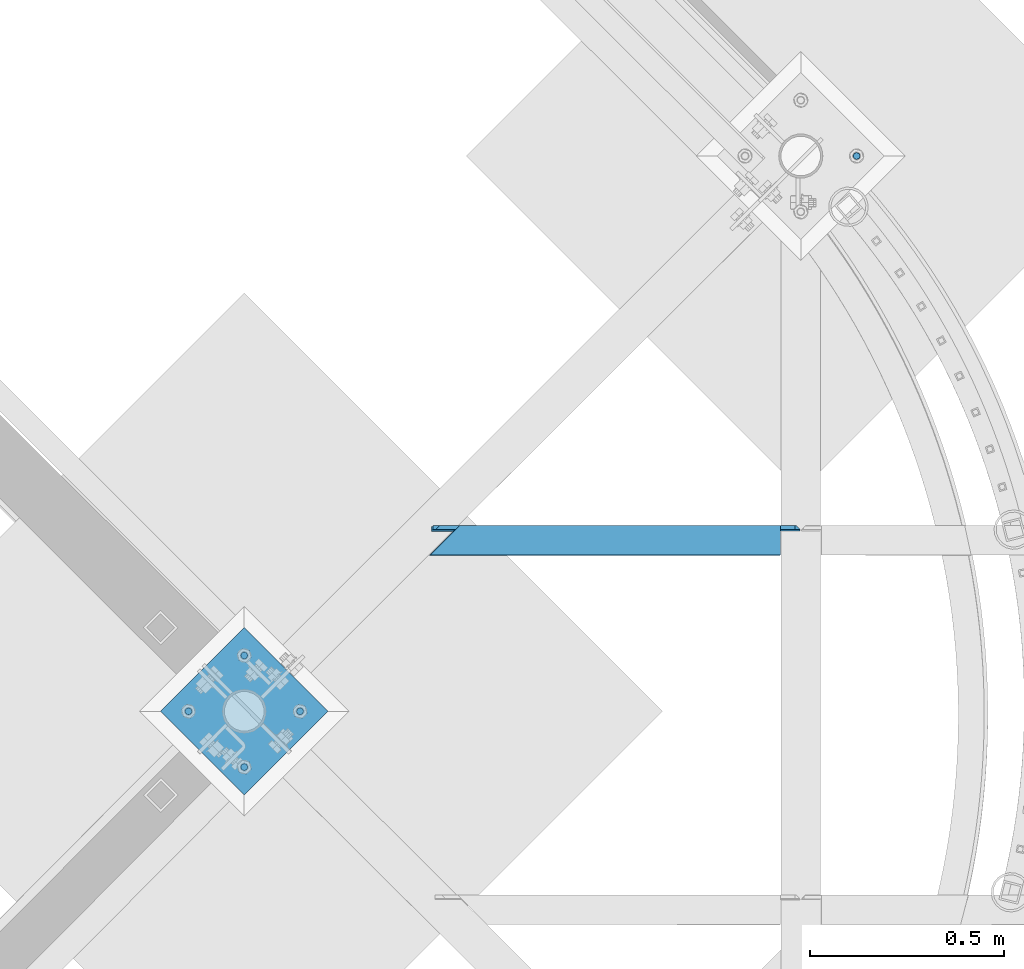
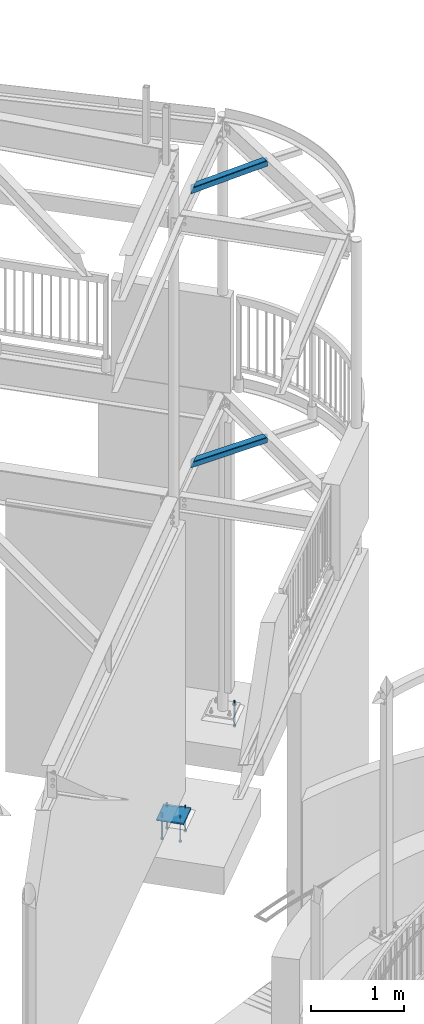
# One storey, part 521 of 975: 9 beams.
"""IFC2X3 building model written with IfcOpenShell, lengths in millimetres."""

from ifc_helpers import new_model, si_unit, frame, origin_with_axes, place, context, subcontext, project, spatial, faceted_brep, material, type_object, element, save


model = new_model("IFC2X3")

# Units and contexts
model_context = context("Model", 3, precision=1e-05, world=origin_with_axes())
body_context = subcontext(model_context, "Body", "Model", "MODEL_VIEW")
ifc_project = project(units=[si_unit("LENGTHUNIT", "METRE", prefix="MILLI"), si_unit("AREAUNIT", "SQUARE_METRE"), si_unit("VOLUMEUNIT", "CUBIC_METRE"), si_unit("MASSUNIT", "GRAM", prefix="KILO"), si_unit("TIMEUNIT", "SECOND"), si_unit("PLANEANGLEUNIT", "RADIAN"), si_unit("SOLIDANGLEUNIT", "STERADIAN"), si_unit("THERMODYNAMICTEMPERATUREUNIT", "DEGREE_CELSIUS"), si_unit("LUMINOUSINTENSITYUNIT", "LUMEN")], contexts=[model_context])

# Site, building, storey
site_placement = place(None, origin_with_axes())
site = spatial("IfcSite", under=ifc_project, at=site_placement, CompositionType="ELEMENT")
building_placement = place(site_placement, origin_with_axes())
building = spatial("IfcBuilding", under=site, at=building_placement, Name="Undefined", CompositionType="ELEMENT")
storey_placement = place(building_placement, origin_with_axes())
storey = spatial("IfcBuildingStorey", under=building, at=storey_placement, Name="Undefined", CompositionType="ELEMENT", Elevation=0.0)

# Beams
ifc_material_1 = material(Name="STEEL/A36")
beam_type_1 = type_object("IfcBeamType", Name="L5X3X3/8", PredefinedType="NOTDEFINED")
beam_1_placement = place(storey_placement, frame((35537.7749999909, 12106.8041668458, 3873.5), z_axis=(0.0, 0.0, -1.0), x_axis=(-0.999999999999998, 6.90000001668524e-08, 0.0)))
element("IfcBeam", 1, at=beam_1_placement, inside=storey, type_object=beam_type_1, material=ifc_material_1, Name="ANGLE", ObjectType="L5X3X3/8", context=body_context, shape_type="Brep", body=[
    faceted_brep([(11.9062518201463, 38.1000002942765, 63.5000000000409), (11.9062518201463, 38.1000000000004, -50.8000004849969), (2.38125152588327, 28.5750000000007, -41.2750001907348), (2.38125152588327, 28.5750000000007, 63.5), (52.3875000000044, -38.1000000000004, -53.9749999999999), (52.3875000000044, -38.1000000000004, -63.5), (955.445198298534, -38.1000000000004, -63.5), (955.445198298941, -38.1000000000004, -53.9749999999999), (52.3875000000044, 28.5750000000007, -53.9749999999999), (888.622206313601, 28.5750000000007, -53.9749999999999), (15.0812513351484, 28.5750000000007, -53.9749999999999), (15.0812513351484, 38.1000000000004, -53.9749999999999), (52.3875000000044, 38.1000000000004, -53.9749999999999), (52.3875000000044, 38.1000000000004, -63.5), (879.076064601009, 38.1000000000004, -63.5), (879.07606460141, 38.1000000000004, -53.9749999995543), (929.646098136363, 38.1000000000004, -53.9749999995488), (939.192239848555, 28.5750000000007, -53.9749999999999), (947.626553754235, 38.1000000000004, -41.2750001902818), (947.626553755501, 28.5750000000007, -48.0176545750301), (947.626553755501, 28.5750003814701, 63.5), (947.626553754235, 38.1000000000004, 63.5)], [[[0, 1, 2, 3]], [[4, 5, 6, 7]], [[8, 4, 7, 9]], [[10, 11, 12, 8]], [[4, 8, 12, 13, 5]], [[5, 13, 14, 6]], [[7, 6, 14, 15, 9]], [[9, 15, 16, 17]], [[17, 16, 18, 19]], [[20, 19, 18, 21]], [[20, 21, 0, 3]], [[10, 8, 9, 17, 19, 20, 3, 2]], [[11, 10, 2, 1]], [[21, 18, 16, 15, 14, 13, 12, 11, 1, 0]]]),
])
beam_2_placement = place(storey_placement, frame((35539.9412127921, 12104.6101987694, 7490.16964449473), z_axis=(0.0341135870818107, -0.0348791829935672, -0.998809143815831), x_axis=(-0.999417962204208, -0.00119054700024391, -0.0340928060069665)))
element("IfcBeam", 2, at=beam_2_placement, inside=storey, type_object=beam_type_1, material=ifc_material_1, Name="ANGLE", ObjectType="L5X3X3/8", context=body_context, shape_type="Brep", body=[
    faceted_brep([(16.248132890425, 38.1000002259043, 63.4999999999727), (12.4534426586179, 38.0999999999676, -47.6721722449001), (3.25891820371908, 28.5749999999734, -37.827783942962), (6.71758545988268, 28.5750000000407, 63.4999999999727), (54.2598028495704, 38.0999999999731, -50.9471839962816), (54.2598028496504, 28.5749999999734, -50.9471839980215), (14.2363025495142, 28.574999999968, -49.5810436898209), (14.236302559053, 38.0999999999676, -49.5810436884067), (54.1564530319665, -38.1000000000258, -53.9749999999822), (53.8313318822111, -38.1000000000313, -63.4999999999791), (957.55596462173, -38.0999999998858, -63.50000000002), (957.881085768073, -38.0999999998821, -53.9750000000231), (54.156453031268, 28.5749999999698, -53.9749999999813), (891.027517890245, 28.5750000001062, -53.9750000000204), (53.831331881418, 38.099999999964, -63.4999999999773), (881.151887132146, 38.100000000095, -63.5000000000155), (881.608963766485, 38.0999998951484, -50.1091301925117), (891.1483590969, 28.575000000108, -50.4347427057555), (939.009241421154, 38.0999999493579, -52.0683999112998), (939.008087242706, 28.5750000001153, -52.1021968201758), (952.135102398344, 28.5749999877098, -39.8086409113939), (952.135102407483, 38.099999965596, -39.8086409100097), (955.661383111757, 38.1000000001932, 63.4999999999309), (955.661383112987, 28.5749998870779, 63.49999999993), (58.1662805450396, 28.5750000000498, 63.4999999999709), (58.1662805449741, 38.1000000000495, 63.4999999999709)], [[[0, 1, 2, 3]], [[4, 5, 6, 7]], [[8, 9, 10, 11]], [[12, 8, 11, 13]], [[5, 4, 14, 9, 8, 12]], [[9, 14, 15, 10]], [[11, 10, 15, 16, 17, 13]], [[17, 16, 18, 19]], [[20, 19, 18, 21]], [[22, 23, 20, 21]], [[24, 23, 22, 25, 0, 3]], [[6, 5, 12, 13, 17, 19, 20, 23, 24, 3, 2]], [[7, 6, 2, 1]], [[25, 22, 21, 18, 16, 15, 14, 4, 7, 1, 0]]]),
])
beam_type_2 = type_object("IfcBeamType", PredefinedType="NOTDEFINED")
beam_3_placement = place(storey_placement, frame((34212.0255734525, 11558.7744265471, -257.175000000002), z_axis=(-0.707106781186548, -0.707106781186548, 0.0), x_axis=(-0.707106781186601, 0.707106781186494, 2.36468622460961e-14)))
element("IfcBeam", 3, at=beam_3_placement, inside=storey, type_object=beam_type_2, material=ifc_material_1, Name="PLATE", context=body_context, shape_type="Brep", body=[
    faceted_brep([(0.0, 9.52499999999964, -152.4), (0.0, 9.52499999999964, 152.4), (304.799999999152, 9.52499999999964, 152.4), (304.799999999152, 9.52499999999964, -152.4), (0.0, -9.52499999999964, 152.4), (304.799999999152, -9.52499999999964, 152.4), (0.0, -9.52499999999964, -152.4), (304.799999999152, -9.52499999999964, -152.4)], [[[0, 1, 2, 3]], [[1, 4, 5, 2]], [[4, 6, 7, 5]], [[6, 0, 3, 7]], [[5, 7, 3, 2]], [[6, 4, 1, 0]]]),
])
ifc_material_2 = material(Name="STEEL/F1554-36")
beam_type_3 = type_object("IfcBeamType", PredefinedType="NOTDEFINED")
beam_4_placement = place(storey_placement, frame((35681.4590946862, 13096.8750013477, -304.799999999999), z_axis=(-0.707106781186601, 0.707106781186494, 2.36468622460961e-14), x_axis=(0.0, 0.0, -1.0)))
element("IfcBeam", 4, at=beam_4_placement, inside=storey, type_object=beam_type_3, material=ifc_material_2, Name="HEADED_ANCHOR_BOLT", context=body_context, shape_type="Brep", body=[
    faceted_brep([(209.543749999999, -9.13000011446275, 15.8100004196049), (209.543749999999, -18.2600002288382, 4.72937244921923e-11), (228.593749999998, -18.2600002288382, 4.72937244921923e-11), (228.593749999998, -9.13000011446275, 15.8100004196049), (209.543749999999, 9.13000011438271, 15.8100004195576), (228.593749999998, 9.13000011438271, 15.8100004195576), (209.543749999999, 18.2600002288382, -4.72937244921923e-11), (228.593749999998, 18.2600002288382, -4.72937244921923e-11), (209.543749999999, 9.13000011446275, -15.8100004196049), (228.593749999998, 9.13000011446275, -15.8100004196049), (209.543749999999, -9.13000011438271, -15.8100004195576), (228.593749999998, -9.13000011438271, -15.8100004195576), (209.543749999999, -4.4776800552936, 9.29799844178979), (209.543749999999, -8.068500660469, 6.43441456491473), (209.543749999999, -10.0612557561763, 2.2964159705416), (209.543749999999, -10.0612557561617, -2.29641597048976), (209.543749999999, -8.0685006604399, -6.4344145648729), (209.543749999999, -4.47768005524995, -9.29799844176705), (209.543749999999, 2.91038304567337e-11, -10.3199996948015), (209.543749999999, 4.4776800552936, -9.29799844178979), (209.543749999999, 8.068500660469, -6.43441456491473), (209.543749999999, 10.0612557561763, -2.2964159705416), (209.543749999999, 10.0612557561617, 2.29641597048976), (209.543749999999, 8.0685006604399, 6.4344145648729), (209.543749999999, 4.47768005524995, 9.29799844176705), (209.543749999999, -2.91038304567337e-11, 10.3199996948015), (228.593749999998, -2.91038304567337e-11, 10.3199996948015), (228.593749999998, -4.4776800552936, 9.29799844178979), (228.593749999998, -8.068500660469, 6.43441456491473), (228.593749999998, -10.0612557561763, 2.2964159705416), (228.593749999998, -10.0612557561617, -2.29641597048976), (228.593749999998, -8.0685006604399, -6.4344145648729), (228.593749999998, -4.47768005524995, -9.29799844176705), (228.593749999998, 2.91038304567337e-11, -10.3199996948015), (228.593749999998, 4.4776800552936, -9.29799844178979), (228.593749999998, 8.068500660469, -6.43441456491473), (228.593749999998, 10.0612557561763, -2.2964159705416), (228.593749999998, 10.0612557561617, 2.29641597048976), (228.593749999998, 8.0685006604399, 6.4344145648729), (228.593749999998, 4.47768005524995, 9.29799844176705), (0.0, -6.73519209080223, 6.73519209080186), (0.0, -9.52499999999964, 0.0), (228.6, -9.52500000000146, 0.0), (228.6, -6.73519209080405, 6.73519209080223), (-9.87109982941227e-13, -1.20792265079217e-13, 9.52499961853027), (228.6, 0.0, 9.52499999999964), (0.0, 6.73519209080223, 6.73519209080186), (228.6, 6.73519209080405, 6.73519209080223), (0.0, 9.52499999999964, 0.0), (228.6, 9.52500000000146, 0.0), (0.0, 6.73519209080223, -6.73519209080186), (228.6, 6.73519209080405, -6.73519209080223), (2.95075507493764e-12, -1.20792265079217e-13, -9.52499961853027), (228.6, 0.0, -9.52499999999964), (-114.297914995421, -6.36396103067818, 6.36396103068091), (-114.297914995421, -2.18278728425503e-11, 8.99999999997999), (-114.297914995421, 6.36396103064908, 6.36396103064817), (-114.297914995421, 8.99999999997817, -2.27373675443232e-11), (-114.297914995421, 6.36396103067818, -6.36396103068091), (-114.297914995421, 2.18278728425503e-11, -8.99999999997999), (-114.297914995421, -6.36396103064908, -6.36396103064817), (-114.297914995421, -8.99999999997817, 2.27373675443232e-11), (0.0149743263646087, 6.36396103067818, -6.36396103067909), (0.0149743263646087, 0.0, -9.0), (0.0149743263646087, -6.36396103067818, -6.36396103067909), (0.0149743263987148, -8.9999995411581, -1.00796984270346e-06), (0.0149743263646087, -6.36396103067818, 6.36396103067909), (0.0149743263646087, 0.0, 9.0), (0.0149743263646087, 6.36396103067818, 6.36396103067909), (0.0149743263987148, 9.0000004588419, -1.00796984270346e-06), (0.0, -6.73519209080223, -6.73519209080186), (228.6, -6.73519209080405, -6.73519209080223)], [[[0, 1, 2, 3]], [[4, 0, 3, 5]], [[6, 4, 5, 7]], [[8, 6, 7, 9]], [[10, 8, 9, 11]], [[0, 4, 6, 8, 10, 1], [12, 13, 14, 15, 16, 17, 18, 19, 20, 21, 22, 23, 24, 25]], [[12, 25, 26, 27]], [[13, 12, 27, 28]], [[14, 13, 28, 29]], [[15, 14, 29, 30]], [[16, 15, 30, 31]], [[17, 16, 31, 32]], [[18, 17, 32, 33]], [[19, 18, 33, 34]], [[20, 19, 34, 35]], [[21, 20, 35, 36]], [[22, 21, 36, 37]], [[23, 22, 37, 38]], [[24, 23, 38, 39]], [[25, 24, 39, 26]], [[9, 7, 5, 3, 2, 11], [38, 37, 36, 35, 34, 33, 32, 31, 30, 29, 28, 27, 26, 39]], [[1, 10, 11, 2]], [[40, 41, 42, 43]], [[44, 40, 43, 45]], [[46, 44, 45, 47]], [[48, 46, 47, 49]], [[50, 48, 49, 51]], [[52, 50, 51, 53]], [[54, 55, 56, 57, 58, 59, 60, 61]], [[59, 58, 62, 63]], [[60, 59, 63, 64]], [[61, 60, 64, 65]], [[54, 61, 65, 66]], [[55, 54, 66, 67]], [[56, 55, 67, 68]], [[57, 56, 68, 69]], [[58, 57, 69, 62]], [[40, 44, 46, 48, 50, 52, 70, 41], [68, 67, 66, 65, 64, 63, 62, 69]], [[41, 70, 71, 42]], [[53, 51, 49, 47, 45, 43, 42, 71]], [[70, 52, 53, 71]]]),
])
beam_5_placement = place(storey_placement, frame((34247.9465946999, 11666.537501079, -304.799999999999), z_axis=(-0.707106781186601, 0.707106781186494, 2.36468622460961e-14), x_axis=(0.0, 0.0, -1.0)))
element("IfcBeam", 5, at=beam_5_placement, inside=storey, type_object=beam_type_3, material=ifc_material_2, Name="HEADED_ANCHOR_BOLT", context=body_context, shape_type="Brep", body=[
    faceted_brep([(209.543749999999, -9.13000011446275, 15.8100004196049), (209.543749999999, -18.2600002288382, 4.72937244921923e-11), (228.593749999998, -18.2600002288382, 4.72937244921923e-11), (228.593749999998, -9.13000011446275, 15.8100004196049), (209.543749999999, 9.13000011438271, 15.8100004195576), (228.593749999998, 9.13000011438271, 15.8100004195576), (209.543749999999, 18.2600002288382, -4.72937244921923e-11), (228.593749999998, 18.2600002288382, -4.72937244921923e-11), (209.543749999999, 9.13000011446275, -15.8100004196049), (228.593749999998, 9.13000011446275, -15.8100004196049), (209.543749999999, -9.13000011438271, -15.8100004195576), (228.593749999998, -9.13000011438271, -15.8100004195576), (209.543749999999, -4.4776800552936, 9.29799844178979), (209.543749999999, -8.068500660469, 6.43441456491473), (209.543749999999, -10.0612557561763, 2.2964159705416), (209.543749999999, -10.0612557561617, -2.29641597048976), (209.543749999999, -8.0685006604399, -6.4344145648729), (209.543749999999, -4.47768005524995, -9.29799844176705), (209.543749999999, 2.91038304567337e-11, -10.3199996948015), (209.543749999999, 4.4776800552936, -9.29799844178979), (209.543749999999, 8.068500660469, -6.43441456491473), (209.543749999999, 10.0612557561763, -2.2964159705416), (209.543749999999, 10.0612557561617, 2.29641597048976), (209.543749999999, 8.0685006604399, 6.4344145648729), (209.543749999999, 4.47768005524995, 9.29799844176705), (209.543749999999, -2.91038304567337e-11, 10.3199996948015), (228.593749999998, -2.91038304567337e-11, 10.3199996948015), (228.593749999998, -4.4776800552936, 9.29799844178979), (228.593749999998, -8.068500660469, 6.43441456491473), (228.593749999998, -10.0612557561763, 2.2964159705416), (228.593749999998, -10.0612557561617, -2.29641597048976), (228.593749999998, -8.0685006604399, -6.4344145648729), (228.593749999998, -4.47768005524995, -9.29799844176705), (228.593749999998, 2.91038304567337e-11, -10.3199996948015), (228.593749999998, 4.4776800552936, -9.29799844178979), (228.593749999998, 8.068500660469, -6.43441456491473), (228.593749999998, 10.0612557561763, -2.2964159705416), (228.593749999998, 10.0612557561617, 2.29641597048976), (228.593749999998, 8.0685006604399, 6.4344145648729), (228.593749999998, 4.47768005524995, 9.29799844176705), (0.0, -6.73519209080223, 6.73519209080186), (0.0, -9.52499999999964, 0.0), (228.6, -9.52500000000146, 0.0), (228.6, -6.73519209080405, 6.73519209080223), (-9.87109982941227e-13, -1.20792265079217e-13, 9.52499961853027), (228.6, 0.0, 9.52499999999964), (0.0, 6.73519209080223, 6.73519209080186), (228.6, 6.73519209080405, 6.73519209080223), (0.0, 9.52499999999964, 0.0), (228.6, 9.52500000000146, 0.0), (0.0, 6.73519209080223, -6.73519209080186), (228.6, 6.73519209080405, -6.73519209080223), (2.95075507493764e-12, -1.20792265079217e-13, -9.52499961853027), (228.6, 0.0, -9.52499999999964), (-114.297914995421, -6.36396103067818, 6.36396103068091), (-114.297914995421, -2.18278728425503e-11, 8.99999999997999), (-114.297914995421, 6.36396103064908, 6.36396103064817), (-114.297914995421, 8.99999999997817, -2.27373675443232e-11), (-114.297914995421, 6.36396103067818, -6.36396103068091), (-114.297914995421, 2.18278728425503e-11, -8.99999999997999), (-114.297914995421, -6.36396103064908, -6.36396103064817), (-114.297914995421, -8.99999999997817, 2.27373675443232e-11), (0.0149743263646087, 6.36396103067818, -6.36396103067909), (0.0149743263646087, 0.0, -9.0), (0.0149743263646087, -6.36396103067818, -6.36396103067909), (0.0149743263987148, -8.9999995411581, -1.00796984270346e-06), (0.0149743263646087, -6.36396103067818, 6.36396103067909), (0.0149743263646087, 0.0, 9.0), (0.0149743263646087, 6.36396103067818, 6.36396103067909), (0.0149743263987148, 9.0000004588419, -1.00796984270346e-06), (0.0, -6.73519209080223, -6.73519209080186), (228.6, -6.73519209080405, -6.73519209080223)], [[[0, 1, 2, 3]], [[4, 0, 3, 5]], [[6, 4, 5, 7]], [[8, 6, 7, 9]], [[10, 8, 9, 11]], [[0, 4, 6, 8, 10, 1], [12, 13, 14, 15, 16, 17, 18, 19, 20, 21, 22, 23, 24, 25]], [[12, 25, 26, 27]], [[13, 12, 27, 28]], [[14, 13, 28, 29]], [[15, 14, 29, 30]], [[16, 15, 30, 31]], [[17, 16, 31, 32]], [[18, 17, 32, 33]], [[19, 18, 33, 34]], [[20, 19, 34, 35]], [[21, 20, 35, 36]], [[22, 21, 36, 37]], [[23, 22, 37, 38]], [[24, 23, 38, 39]], [[25, 24, 39, 26]], [[9, 7, 5, 3, 2, 11], [38, 37, 36, 35, 34, 33, 32, 31, 30, 29, 28, 27, 26, 39]], [[1, 10, 11, 2]], [[40, 41, 42, 43]], [[44, 40, 43, 45]], [[46, 44, 45, 47]], [[48, 46, 47, 49]], [[50, 48, 49, 51]], [[52, 50, 51, 53]], [[54, 55, 56, 57, 58, 59, 60, 61]], [[59, 58, 62, 63]], [[60, 59, 63, 64]], [[61, 60, 64, 65]], [[54, 61, 65, 66]], [[55, 54, 66, 67]], [[56, 55, 67, 68]], [[57, 56, 68, 69]], [[58, 57, 69, 62]], [[40, 44, 46, 48, 50, 52, 70, 41], [68, 67, 66, 65, 64, 63, 62, 69]], [[41, 70, 71, 42]], [[53, 51, 49, 47, 45, 43, 42, 71]], [[70, 52, 53, 71]]]),
])
beam_6_placement = place(storey_placement, frame((34104.262498921, 11522.8534052998, -304.799999999999), z_axis=(-0.707106781186601, 0.707106781186494, 2.36468622460961e-14), x_axis=(0.0, 0.0, -1.0)))
element("IfcBeam", 6, at=beam_6_placement, inside=storey, type_object=beam_type_3, material=ifc_material_2, Name="HEADED_ANCHOR_BOLT", context=body_context, shape_type="Brep", body=[
    faceted_brep([(209.543749999999, 9.13000011446275, -15.8100004196049), (209.543749999999, 18.2600002288382, -4.72937244921923e-11), (228.593749999998, 18.2600002288382, -4.72937244921923e-11), (228.593749999998, 9.13000011446275, -15.8100004196049), (209.543749999999, -9.13000011438271, -15.8100004195576), (228.593749999998, -9.13000011438271, -15.8100004195576), (209.543749999999, -18.2600002288382, 4.72937244921923e-11), (228.593749999998, -18.2600002288382, 4.72937244921923e-11), (209.543749999999, -9.13000011446275, 15.8100004196049), (228.593749999998, -9.13000011446275, 15.8100004196049), (209.543749999999, 9.13000011438271, 15.8100004195576), (228.593749999998, 9.13000011438271, 15.8100004195576), (209.543749999999, -4.4776800552936, 9.29799844178979), (209.543749999999, -8.068500660469, 6.43441456491473), (209.543749999999, -10.0612557561763, 2.2964159705416), (209.543749999999, -10.0612557561617, -2.29641597048976), (209.543749999999, -8.0685006604399, -6.4344145648729), (209.543749999999, -4.47768005524995, -9.29799844176705), (209.543749999999, 2.91038304567337e-11, -10.3199996948015), (209.543749999999, 4.4776800552936, -9.29799844178979), (209.543749999999, 8.068500660469, -6.43441456491473), (209.543749999999, 10.0612557561763, -2.2964159705416), (209.543749999999, 10.0612557561617, 2.29641597048976), (209.543749999999, 8.0685006604399, 6.4344145648729), (209.543749999999, 4.47768005524995, 9.29799844176705), (209.543749999999, -2.91038304567337e-11, 10.3199996948015), (228.593749999998, 2.91038304567337e-11, -10.3199996948015), (228.593749999998, 4.4776800552936, -9.29799844178979), (228.593749999998, 8.068500660469, -6.43441456491473), (228.593749999998, 10.0612557561763, -2.2964159705416), (228.593749999998, 10.0612557561617, 2.29641597048976), (228.593749999998, 8.0685006604399, 6.4344145648729), (228.593749999998, 4.47768005524995, 9.29799844176705), (228.593749999998, -2.91038304567337e-11, 10.3199996948015), (228.593749999998, -4.4776800552936, 9.29799844178979), (228.593749999998, -8.068500660469, 6.43441456491473), (228.593749999998, -10.0612557561763, 2.2964159705416), (228.593749999998, -10.0612557561617, -2.29641597048976), (228.593749999998, -8.0685006604399, -6.4344145648729), (228.593749999998, -4.47768005524995, -9.29799844176705), (0.0, -6.73519209080223, 6.73519209080186), (0.0, -9.52499999999964, 0.0), (228.6, -9.52500000000146, 0.0), (228.6, -6.73519209080405, 6.73519209080223), (-9.87109982941227e-13, -1.20792265079217e-13, 9.52499961853027), (228.6, 0.0, 9.52499999999964), (0.0, 6.73519209080223, 6.73519209080186), (228.6, 6.73519209080405, 6.73519209080223), (0.0, 9.52499999999964, 0.0), (228.6, 9.52500000000146, 0.0), (0.0, 6.73519209080223, -6.73519209080186), (228.6, 6.73519209080405, -6.73519209080223), (2.95075507493764e-12, -1.20792265079217e-13, -9.52499961853027), (228.6, 0.0, -9.52499999999964), (-114.297914995421, -6.36396103067818, 6.36396103068091), (-114.297914995421, -2.18278728425503e-11, 8.99999999997999), (-114.297914995421, 6.36396103064908, 6.36396103064817), (-114.297914995421, 8.99999999997817, -2.27373675443232e-11), (-114.297914995421, 6.36396103067818, -6.36396103068091), (-114.297914995421, 2.18278728425503e-11, -8.99999999997999), (-114.297914995421, -6.36396103064908, -6.36396103064817), (-114.297914995421, -8.99999999997817, 2.27373675443232e-11), (0.0149743263646087, 6.36396103067818, -6.36396103067909), (0.0149743263646087, 0.0, -9.0), (0.0149743263646087, -6.36396103067818, -6.36396103067909), (0.0149743263987148, -8.9999995411581, -1.00796984270346e-06), (0.0149743263646087, -6.36396103067818, 6.36396103067909), (0.0149743263646087, 0.0, 9.0), (0.0149743263646087, 6.36396103067818, 6.36396103067909), (0.0149743263987148, 9.0000004588419, -1.00796984270346e-06), (0.0, -6.73519209080223, -6.73519209080186), (228.6, -6.73519209080405, -6.73519209080223)], [[[0, 1, 2, 3]], [[4, 0, 3, 5]], [[6, 4, 5, 7]], [[8, 6, 7, 9]], [[10, 8, 9, 11]], [[8, 10, 1, 0, 4, 6], [12, 13, 14, 15, 16, 17, 18, 19, 20, 21, 22, 23, 24, 25]], [[19, 18, 26, 27]], [[20, 19, 27, 28]], [[21, 20, 28, 29]], [[22, 21, 29, 30]], [[23, 22, 30, 31]], [[24, 23, 31, 32]], [[25, 24, 32, 33]], [[12, 25, 33, 34]], [[13, 12, 34, 35]], [[14, 13, 35, 36]], [[15, 14, 36, 37]], [[16, 15, 37, 38]], [[17, 16, 38, 39]], [[18, 17, 39, 26]], [[3, 2, 11, 9, 7, 5], [31, 30, 29, 28, 27, 26, 39, 38, 37, 36, 35, 34, 33, 32]], [[1, 10, 11, 2]], [[40, 41, 42, 43]], [[44, 40, 43, 45]], [[46, 44, 45, 47]], [[48, 46, 47, 49]], [[50, 48, 49, 51]], [[52, 50, 51, 53]], [[54, 55, 56, 57, 58, 59, 60, 61]], [[59, 58, 62, 63]], [[60, 59, 63, 64]], [[61, 60, 64, 65]], [[54, 61, 65, 66]], [[55, 54, 66, 67]], [[56, 55, 67, 68]], [[57, 56, 68, 69]], [[58, 57, 69, 62]], [[40, 44, 46, 48, 50, 52, 70, 41], [68, 67, 66, 65, 64, 63, 62, 69]], [[41, 70, 71, 42]], [[53, 51, 49, 47, 45, 43, 42, 71]], [[70, 52, 53, 71]]]),
])
beam_7_placement = place(storey_placement, frame((33960.5784031422, 11666.537501079, -304.799999999999), z_axis=(-0.707106781186601, 0.707106781186494, 2.36468622460961e-14), x_axis=(0.0, 0.0, -1.0)))
element("IfcBeam", 7, at=beam_7_placement, inside=storey, type_object=beam_type_3, material=ifc_material_2, Name="HEADED_ANCHOR_BOLT", context=body_context, shape_type="Brep", body=[
    faceted_brep([(209.543749999999, 9.13000011446275, -15.8100004196049), (209.543749999999, 18.2600002288382, -4.72937244921923e-11), (228.593749999998, 18.2600002288382, -4.72937244921923e-11), (228.593749999998, 9.13000011446275, -15.8100004196049), (209.543749999999, -9.13000011438271, -15.8100004195576), (228.593749999998, -9.13000011438271, -15.8100004195576), (209.543749999999, -18.2600002288382, 4.72937244921923e-11), (228.593749999998, -18.2600002288382, 4.72937244921923e-11), (209.543749999999, -9.13000011446275, 15.8100004196049), (228.593749999998, -9.13000011446275, 15.8100004196049), (209.543749999999, 9.13000011438271, 15.8100004195576), (228.593749999998, 9.13000011438271, 15.8100004195576), (209.543749999999, -4.4776800552936, 9.29799844178979), (209.543749999999, -8.068500660469, 6.43441456491473), (209.543749999999, -10.0612557561763, 2.2964159705416), (209.543749999999, -10.0612557561617, -2.29641597048976), (209.543749999999, -8.0685006604399, -6.4344145648729), (209.543749999999, -4.47768005524995, -9.29799844176705), (209.543749999999, 2.91038304567337e-11, -10.3199996948015), (209.543749999999, 4.4776800552936, -9.29799844178979), (209.543749999999, 8.068500660469, -6.43441456491473), (209.543749999999, 10.0612557561763, -2.2964159705416), (209.543749999999, 10.0612557561617, 2.29641597048976), (209.543749999999, 8.0685006604399, 6.4344145648729), (209.543749999999, 4.47768005524995, 9.29799844176705), (209.543749999999, -2.91038304567337e-11, 10.3199996948015), (228.593749999998, 2.91038304567337e-11, -10.3199996948015), (228.593749999998, 4.4776800552936, -9.29799844178979), (228.593749999998, 8.068500660469, -6.43441456491473), (228.593749999998, 10.0612557561763, -2.2964159705416), (228.593749999998, 10.0612557561617, 2.29641597048976), (228.593749999998, 8.0685006604399, 6.4344145648729), (228.593749999998, 4.47768005524995, 9.29799844176705), (228.593749999998, -2.91038304567337e-11, 10.3199996948015), (228.593749999998, -4.4776800552936, 9.29799844178979), (228.593749999998, -8.068500660469, 6.43441456491473), (228.593749999998, -10.0612557561763, 2.2964159705416), (228.593749999998, -10.0612557561617, -2.29641597048976), (228.593749999998, -8.0685006604399, -6.4344145648729), (228.593749999998, -4.47768005524995, -9.29799844176705), (0.0, -6.73519209080223, 6.73519209080186), (0.0, -9.52499999999964, 0.0), (228.6, -9.52500000000146, 0.0), (228.6, -6.73519209080405, 6.73519209080223), (-9.87109982941227e-13, -1.20792265079217e-13, 9.52499961853027), (228.6, 0.0, 9.52499999999964), (0.0, 6.73519209080223, 6.73519209080186), (228.6, 6.73519209080405, 6.73519209080223), (0.0, 9.52499999999964, 0.0), (228.6, 9.52500000000146, 0.0), (0.0, 6.73519209080223, -6.73519209080186), (228.6, 6.73519209080405, -6.73519209080223), (2.95075507493764e-12, -1.20792265079217e-13, -9.52499961853027), (228.6, 0.0, -9.52499999999964), (-114.297914995421, -6.36396103067818, 6.36396103068091), (-114.297914995421, -2.18278728425503e-11, 8.99999999997999), (-114.297914995421, 6.36396103064908, 6.36396103064817), (-114.297914995421, 8.99999999997817, -2.27373675443232e-11), (-114.297914995421, 6.36396103067818, -6.36396103068091), (-114.297914995421, 2.18278728425503e-11, -8.99999999997999), (-114.297914995421, -6.36396103064908, -6.36396103064817), (-114.297914995421, -8.99999999997817, 2.27373675443232e-11), (0.0149743263646087, 6.36396103067818, -6.36396103067909), (0.0149743263646087, 0.0, -9.0), (0.0149743263646087, -6.36396103067818, -6.36396103067909), (0.0149743263987148, -8.9999995411581, -1.00796984270346e-06), (0.0149743263646087, -6.36396103067818, 6.36396103067909), (0.0149743263646087, 0.0, 9.0), (0.0149743263646087, 6.36396103067818, 6.36396103067909), (0.0149743263987148, 9.0000004588419, -1.00796984270346e-06), (0.0, -6.73519209080223, -6.73519209080186), (228.6, -6.73519209080405, -6.73519209080223)], [[[0, 1, 2, 3]], [[4, 0, 3, 5]], [[6, 4, 5, 7]], [[8, 6, 7, 9]], [[10, 8, 9, 11]], [[8, 10, 1, 0, 4, 6], [12, 13, 14, 15, 16, 17, 18, 19, 20, 21, 22, 23, 24, 25]], [[19, 18, 26, 27]], [[20, 19, 27, 28]], [[21, 20, 28, 29]], [[22, 21, 29, 30]], [[23, 22, 30, 31]], [[24, 23, 31, 32]], [[25, 24, 32, 33]], [[12, 25, 33, 34]], [[13, 12, 34, 35]], [[14, 13, 35, 36]], [[15, 14, 36, 37]], [[16, 15, 37, 38]], [[17, 16, 38, 39]], [[18, 17, 39, 26]], [[3, 2, 11, 9, 7, 5], [31, 30, 29, 28, 27, 26, 39, 38, 37, 36, 35, 34, 33, 32]], [[1, 10, 11, 2]], [[40, 41, 42, 43]], [[44, 40, 43, 45]], [[46, 44, 45, 47]], [[48, 46, 47, 49]], [[50, 48, 49, 51]], [[52, 50, 51, 53]], [[54, 55, 56, 57, 58, 59, 60, 61]], [[59, 58, 62, 63]], [[60, 59, 63, 64]], [[61, 60, 64, 65]], [[54, 61, 65, 66]], [[55, 54, 66, 67]], [[56, 55, 67, 68]], [[57, 56, 68, 69]], [[58, 57, 69, 62]], [[40, 44, 46, 48, 50, 52, 70, 41], [68, 67, 66, 65, 64, 63, 62, 69]], [[41, 70, 71, 42]], [[53, 51, 49, 47, 45, 43, 42, 71]], [[70, 52, 53, 71]]]),
])
beam_8_placement = place(storey_placement, frame((34104.262498921, 11810.2215968582, -304.799999999999), z_axis=(-0.707106781186601, 0.707106781186494, 2.36468622460961e-14), x_axis=(0.0, 0.0, -1.0)))
element("IfcBeam", 8, at=beam_8_placement, inside=storey, type_object=beam_type_3, material=ifc_material_2, Name="HEADED_ANCHOR_BOLT", context=body_context, shape_type="Brep", body=[
    faceted_brep([(209.543749999999, -9.13000011446275, 15.8100004196049), (209.543749999999, -18.2600002288382, 4.72937244921923e-11), (228.593749999998, -18.2600002288382, 4.72937244921923e-11), (228.593749999998, -9.13000011446275, 15.8100004196049), (209.543749999999, 9.13000011438271, 15.8100004195576), (228.593749999998, 9.13000011438271, 15.8100004195576), (209.543749999999, 18.2600002288382, -4.72937244921923e-11), (228.593749999998, 18.2600002288382, -4.72937244921923e-11), (209.543749999999, 9.13000011446275, -15.8100004196049), (228.593749999998, 9.13000011446275, -15.8100004196049), (209.543749999999, -9.13000011438271, -15.8100004195576), (228.593749999998, -9.13000011438271, -15.8100004195576), (209.543749999999, -4.4776800552936, 9.29799844178979), (209.543749999999, -8.068500660469, 6.43441456491473), (209.543749999999, -10.0612557561763, 2.2964159705416), (209.543749999999, -10.0612557561617, -2.29641597048976), (209.543749999999, -8.0685006604399, -6.4344145648729), (209.543749999999, -4.47768005524995, -9.29799844176705), (209.543749999999, 2.91038304567337e-11, -10.3199996948015), (209.543749999999, 4.4776800552936, -9.29799844178979), (209.543749999999, 8.068500660469, -6.43441456491473), (209.543749999999, 10.0612557561763, -2.2964159705416), (209.543749999999, 10.0612557561617, 2.29641597048976), (209.543749999999, 8.0685006604399, 6.4344145648729), (209.543749999999, 4.47768005524995, 9.29799844176705), (209.543749999999, -2.91038304567337e-11, 10.3199996948015), (228.593749999998, -2.91038304567337e-11, 10.3199996948015), (228.593749999998, -4.4776800552936, 9.29799844178979), (228.593749999998, -8.068500660469, 6.43441456491473), (228.593749999998, -10.0612557561763, 2.2964159705416), (228.593749999998, -10.0612557561617, -2.29641597048976), (228.593749999998, -8.0685006604399, -6.4344145648729), (228.593749999998, -4.47768005524995, -9.29799844176705), (228.593749999998, 2.91038304567337e-11, -10.3199996948015), (228.593749999998, 4.4776800552936, -9.29799844178979), (228.593749999998, 8.068500660469, -6.43441456491473), (228.593749999998, 10.0612557561763, -2.2964159705416), (228.593749999998, 10.0612557561617, 2.29641597048976), (228.593749999998, 8.0685006604399, 6.4344145648729), (228.593749999998, 4.47768005524995, 9.29799844176705), (0.0, -6.73519209080223, 6.73519209080186), (0.0, -9.52499999999964, 0.0), (228.6, -9.52500000000146, 0.0), (228.6, -6.73519209080405, 6.73519209080223), (-9.87109982941227e-13, -1.20792265079217e-13, 9.52499961853027), (228.6, 0.0, 9.52499999999964), (0.0, 6.73519209080223, 6.73519209080186), (228.6, 6.73519209080405, 6.73519209080223), (0.0, 9.52499999999964, 0.0), (228.6, 9.52500000000146, 0.0), (0.0, 6.73519209080223, -6.73519209080186), (228.6, 6.73519209080405, -6.73519209080223), (2.95075507493764e-12, -1.20792265079217e-13, -9.52499961853027), (228.6, 0.0, -9.52499999999964), (-114.297914995421, -6.36396103067818, 6.36396103068091), (-114.297914995421, -2.18278728425503e-11, 8.99999999997999), (-114.297914995421, 6.36396103064908, 6.36396103064817), (-114.297914995421, 8.99999999997817, -2.27373675443232e-11), (-114.297914995421, 6.36396103067818, -6.36396103068091), (-114.297914995421, 2.18278728425503e-11, -8.99999999997999), (-114.297914995421, -6.36396103064908, -6.36396103064817), (-114.297914995421, -8.99999999997817, 2.27373675443232e-11), (0.0149743263646087, 6.36396103067818, -6.36396103067909), (0.0149743263646087, 0.0, -9.0), (0.0149743263646087, -6.36396103067818, -6.36396103067909), (0.0149743263987148, -8.9999995411581, -1.00796984270346e-06), (0.0149743263646087, -6.36396103067818, 6.36396103067909), (0.0149743263646087, 0.0, 9.0), (0.0149743263646087, 6.36396103067818, 6.36396103067909), (0.0149743263987148, 9.0000004588419, -1.00796984270346e-06), (0.0, -6.73519209080223, -6.73519209080186), (228.6, -6.73519209080405, -6.73519209080223)], [[[0, 1, 2, 3]], [[4, 0, 3, 5]], [[6, 4, 5, 7]], [[8, 6, 7, 9]], [[10, 8, 9, 11]], [[0, 4, 6, 8, 10, 1], [12, 13, 14, 15, 16, 17, 18, 19, 20, 21, 22, 23, 24, 25]], [[12, 25, 26, 27]], [[13, 12, 27, 28]], [[14, 13, 28, 29]], [[15, 14, 29, 30]], [[16, 15, 30, 31]], [[17, 16, 31, 32]], [[18, 17, 32, 33]], [[19, 18, 33, 34]], [[20, 19, 34, 35]], [[21, 20, 35, 36]], [[22, 21, 36, 37]], [[23, 22, 37, 38]], [[24, 23, 38, 39]], [[25, 24, 39, 26]], [[9, 7, 5, 3, 2, 11], [38, 37, 36, 35, 34, 33, 32, 31, 30, 29, 28, 27, 26, 39]], [[1, 10, 11, 2]], [[40, 41, 42, 43]], [[44, 40, 43, 45]], [[46, 44, 45, 47]], [[48, 46, 47, 49]], [[50, 48, 49, 51]], [[52, 50, 51, 53]], [[54, 55, 56, 57, 58, 59, 60, 61]], [[59, 58, 62, 63]], [[60, 59, 63, 64]], [[61, 60, 64, 65]], [[54, 61, 65, 66]], [[55, 54, 66, 67]], [[56, 55, 67, 68]], [[57, 56, 68, 69]], [[58, 57, 69, 62]], [[40, 44, 46, 48, 50, 52, 70, 41], [68, 67, 66, 65, 64, 63, 62, 69]], [[41, 70, 71, 42]], [[53, 51, 49, 47, 45, 43, 42, 71]], [[70, 52, 53, 71]]]),
])
beam_type_4 = type_object("IfcBeamType", PredefinedType="NOTDEFINED")
beam_9_placement = place(storey_placement, frame((34212.0255734525, 11558.7744265471, -265.112500000001), z_axis=(-0.707106781186548, -0.707106781186548, 0.0), x_axis=(-0.707106781186601, 0.707106781186494, 2.36468622460961e-14)))
element("IfcBeam", 9, at=beam_9_placement, inside=storey, type_object=beam_type_4, material=ifc_material_1, Name="TEMPLATE", context=body_context, shape_type="Brep", body=[
    faceted_brep([(0.0, 1.58750000000009, -152.4), (0.0, 1.58750000000009, 152.4), (304.799999999153, 1.58750000000001, 152.400000000001), (304.799999999153, 1.58750000000001, -152.400000000001), (0.0, -1.58750000000009, 152.4), (304.799999999153, -1.58750000000001, 152.400000000001), (0.0, -1.58750000000009, -152.4), (304.799999999153, -1.58750000000001, -152.400000000001)], [[[0, 1, 2, 3]], [[1, 4, 5, 2]], [[4, 6, 7, 5]], [[6, 0, 3, 7]], [[5, 7, 3, 2]], [[6, 4, 1, 0]]]),
])

save(model, "model.ifc")
